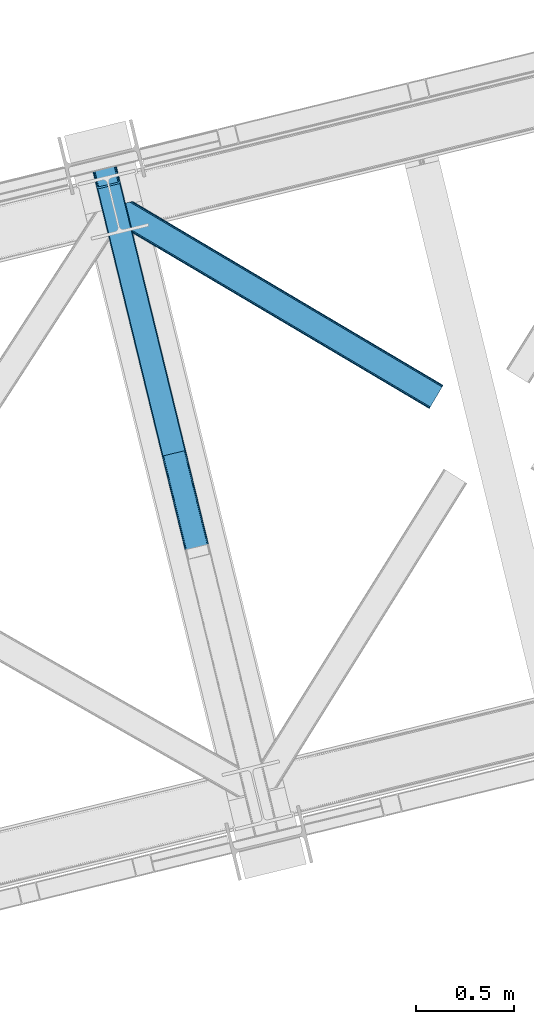
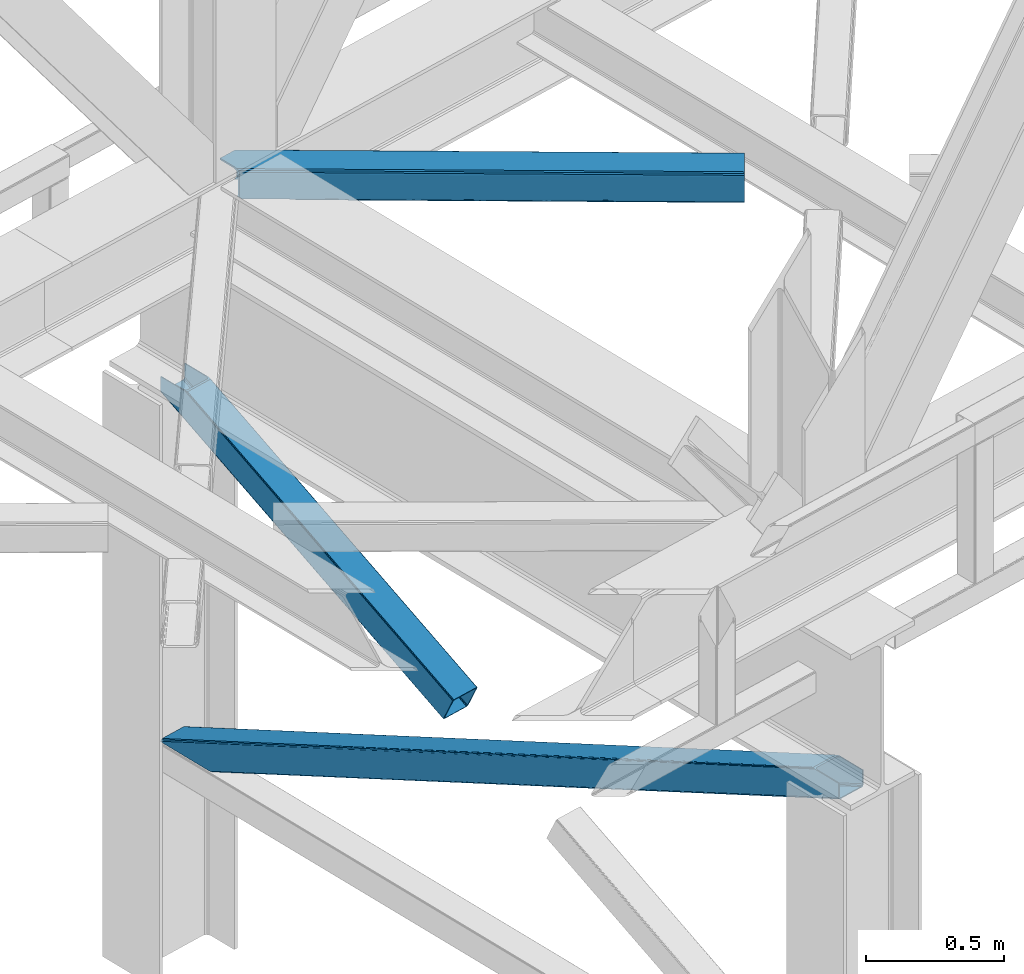
# One storey, part 56 of 93: 3 members.
"""IFC4 building model written with IfcOpenShell, lengths in millimetres."""

from ifc_helpers import new_model, entity, si_unit, converted_unit, derived_unit, direction, frame, origin, place, context, subcontext, project, spatial, triangles, polygons, type_object, element, save


model = new_model("IFC4")

# Units and contexts
model_context = context("Model", 3, precision=0.01, world=origin(), true_north=direction((6.12303176911189e-17, 1.0)))
plan_context = context("Plan", 3, precision=0.01, world=origin(), true_north=direction((6.12303176911189e-17, 1.0)))
body_context = subcontext(model_context, "Body", "Model", "MODEL_VIEW")
ifc_project = project(units=[si_unit("LENGTHUNIT", "METRE", prefix="MILLI"), si_unit("AREAUNIT", "SQUARE_METRE"), si_unit("VOLUMEUNIT", "CUBIC_METRE"), converted_unit("PLANEANGLEUNIT", "DEGREE", entity("IfcRatioMeasure", 0.0174532925199433), si_unit("PLANEANGLEUNIT", "RADIAN"), dimensions=[0, 0, 0, 0, 0, 0, 0]), si_unit("MASSUNIT", "GRAM", prefix="KILO"), derived_unit("MASSDENSITYUNIT", [(si_unit("MASSUNIT", "GRAM", prefix="KILO"), 1), (si_unit("LENGTHUNIT", "METRE"), -3)]), derived_unit("MOMENTOFINERTIAUNIT", [(si_unit("LENGTHUNIT", "METRE"), 4)]), si_unit("TIMEUNIT", "SECOND"), si_unit("FREQUENCYUNIT", "HERTZ"), si_unit("THERMODYNAMICTEMPERATUREUNIT", "DEGREE_CELSIUS"), derived_unit("THERMALTRANSMITTANCEUNIT", [(si_unit("MASSUNIT", "GRAM", prefix="KILO"), 1), (si_unit("THERMODYNAMICTEMPERATUREUNIT", "KELVIN"), -1), (si_unit("TIMEUNIT", "SECOND"), -3)]), derived_unit("VOLUMETRICFLOWRATEUNIT", [(si_unit("LENGTHUNIT", "METRE"), 3), (si_unit("TIMEUNIT", "SECOND"), -1)]), derived_unit("MASSFLOWRATEUNIT", [(si_unit("MASSUNIT", "GRAM", prefix="KILO"), 1), (si_unit("TIMEUNIT", "SECOND"), -1)]), derived_unit("ROTATIONALFREQUENCYUNIT", [(si_unit("TIMEUNIT", "SECOND"), -1)]), si_unit("ELECTRICCURRENTUNIT", "AMPERE"), si_unit("ELECTRICVOLTAGEUNIT", "VOLT"), si_unit("POWERUNIT", "WATT"), si_unit("FORCEUNIT", "NEWTON", prefix="KILO"), si_unit("ILLUMINANCEUNIT", "LUX"), si_unit("LUMINOUSFLUXUNIT", "LUMEN"), si_unit("LUMINOUSINTENSITYUNIT", "CANDELA"), derived_unit("USERDEFINED", [(si_unit("MASSUNIT", "GRAM", prefix="KILO"), -1), (si_unit("LENGTHUNIT", "METRE"), -2), (si_unit("TIMEUNIT", "SECOND"), 3), (si_unit("LUMINOUSFLUXUNIT", "LUMEN"), 1)]), derived_unit("LINEARVELOCITYUNIT", [(si_unit("LENGTHUNIT", "METRE"), 1), (si_unit("TIMEUNIT", "SECOND"), -1)]), si_unit("PRESSUREUNIT", "PASCAL"), derived_unit("USERDEFINED", [(si_unit("LENGTHUNIT", "METRE"), -2), (si_unit("MASSUNIT", "GRAM", prefix="KILO"), 1), (si_unit("TIMEUNIT", "SECOND"), -2)]), derived_unit("LINEARFORCEUNIT", [(si_unit("MASSUNIT", "GRAM", prefix="KILO"), 1), (si_unit("LENGTHUNIT", "METRE"), 1), (si_unit("TIMEUNIT", "SECOND"), -2), (si_unit("LENGTHUNIT", "METRE"), -1)]), derived_unit("PLANARFORCEUNIT", [(si_unit("MASSUNIT", "GRAM", prefix="KILO"), 1), (si_unit("LENGTHUNIT", "METRE"), 1), (si_unit("TIMEUNIT", "SECOND"), -2), (si_unit("LENGTHUNIT", "METRE"), -2)])], contexts=[model_context, plan_context])

# Site, building, storey
site_placement = place(None, origin())
site = spatial("IfcSite", under=ifc_project, at=site_placement, CompositionType="ELEMENT")
building_placement = place(site_placement, origin())
building = spatial("IfcBuilding", under=site, at=building_placement, CompositionType="ELEMENT")
storey_placement = place(building_placement, frame((0.0, 0.0, 15900.0)))
storey = spatial("IfcBuildingStorey", under=building, at=storey_placement, CompositionType="ELEMENT", Elevation=15900.0)

# Members
member_type_1 = type_object("IfcMemberType", PredefinedType="BRACE")
member_1_placement = place(storey_placement, frame((-30279.2253679732, 12158.5406038661, 1820.90870290301)))
element("IfcMember", 1, at=member_1_placement, inside=storey, type_object=member_type_1, ObjectType="Steel Vertical Brace", PredefinedType="BRACE", context=body_context, shape_type="Tessellation", body=[
    polygons([(29.8135191782847, 1388.61826467864, 771.091297096984), (32.1113287327985, 1381.7631169139, 771.091297096991), (368.111452939622, 3.36089743274636, 105.060837153753), (367.211709770158, 4.48063717440627, 102.289544138114), (35.2425975620341, 1376.24004026086, 771.091297096982), (370.057498317433, 2.70006492288447, 107.410225929579), (38.7306183717297, 1372.88987307312, 771.091297096984), (372.753578135712, 2.59874540397378, 108.980037321763), (42.0443716126254, 1372.22264793569, 771.091297096984), (375.789238682203, 3.07236385431457, 109.531281776207), (140.171129484908, 1396.14208332771, 771.091297096984), (473.91599655449, 26.9917992463367, 109.531281776209), (142.806126265313, 1398.25937921937, 771.091297096991), (476.829086029299, 27.9682515502241, 108.980037321767), (144.361212211709, 1402.83885703392, 771.091297096989), (479.176112967103, 29.2988816959484, 107.410225929583), (144.599639585688, 1409.18333278718, 771.091297096997), (480.599763792512, 30.7811133060244, 105.060837153757), (143.485109980843, 1416.32691755851, 771.091297096984), (480.883300572716, 32.1892900542756, 102.289544138114), (149.600536198007, 1408.12910918704, 771.091297096982), (121.444007267685, 1523.63806044727, 771.091297096982), (117.557799035124, 1522.69075607531, 771.09129709698), (3.88620823256572, 1494.98210319544, 771.091297096982), (4.33146851719357e-12, 1494.03479882348, 771.091297096982), (28.1565289303171, 1378.52584756325, 771.091297096982), (30.4543384848396, 1371.67069979849, 771.091297096982), (33.5856073140622, 1366.14762314545, 771.091297096982), (37.0736281237621, 1362.79745595771, 771.091297096984), (40.3873813646535, 1362.13023082029, 771.09129709698), (146.286555702076, 1387.94427495624, 771.09129709698), (148.921552482481, 1390.06157084789, 771.091297096984), (150.476638428877, 1394.64104866244, 771.09129709698), (150.715065802839, 1400.9855244157, 771.09129709698), (359.725704690142, 52.0811507006333, 4.33146851719357e-12), (465.62487902756, 77.8951948365822, 2.16573425859679e-12), (468.660539574047, 78.3688132869209, 0.551244454446396), (471.356619392343, 78.2674937680102, 2.12105584662818), (473.302664770137, 77.6066612581461, 4.4704446224671), (474.202407939605, 76.4869215164862, 7.24173763810153), (485.172065028735, 31.4851533942308, 105.910412957166), (484.888528248512, 30.0769766459796, 108.681705972796), (483.464877423122, 28.5947450359037, 111.031094748631), (481.117850485317, 27.264114890175, 112.600906140819), (478.204761010512, 26.2876625862897, 113.152150595261), (372.305586673086, 0.473618450342957, 113.152150595257), (369.269926126603, 2.16573425859679e-12, 112.600906140819), (366.573846308307, 0.101319518910685, 111.031094748635), (364.627800930509, 0.76215202877691, 108.681705972796), (363.728057761041, 1.88189177043682, 105.910412957166), (352.758400671911, 46.8836598926922, 7.24173763810153), (353.041937452142, 48.2918366409434, 4.4704446224671), (354.465588277524, 49.7740682510194, 2.12105584662385), (356.812615215332, 51.1046983967459, 0.551244454448562), (470.718755930487, 73.8881761125124, 10.8626064571491), (469.819012761023, 75.0079158541745, 8.09131344151462), (467.872967383238, 75.6687483640451, 5.74192466567137), (465.176887564938, 75.7700678829471, 4.17211327349608), (462.141227018446, 75.2964494326106, 3.62086881905185), (364.01446914616, 51.3770140405885, 3.62086881905185), (361.101379671355, 50.4005617367011, 4.17211327349392), (358.754352733542, 49.0699315909703, 5.7419246656757), (357.330701908156, 47.5876999808965, 8.09131344151245), (357.047165127938, 46.1795232326431, 10.8626064571491), (3.88620823256139, 1494.98210319544, 710.909831470177), (117.557799035124, 1522.69075607531, 710.909831470177), (11.6586246977015, 1496.87671193937, 702.072173549059), (8.91066050334255, 1496.2068665941, 703.366418586696), (6.1626963089966, 1495.53702124884, 704.660663624352), (5.02445227078549, 1495.25956222214, 707.785247547262), (116.4195549969, 1522.41329704861, 707.785247547264), (115.281310958689, 1522.13583802191, 704.660663624352), (112.533346764338, 1521.46599267665, 703.3664185867), (109.785382569988, 1520.79614733139, 702.072173549057), (120.30576322947, 1523.36060142057, 703.366418586702), (119.167519191254, 1523.08314239387, 700.241834663787), (116.419554996908, 1522.41329704861, 698.94758962614), (113.671590802554, 1521.74345170335, 697.653344588497), (7.77241646513577, 1495.9294075674, 697.653344588497), (5.02445227078549, 1495.25956222214, 698.94758962614), (2.27648807643521, 1494.58971687688, 700.241834663785), (1.13824403821544, 1494.31225785018, 703.366418586702), (4.33146851719357e-12, 1494.03479882348, 706.491002509615), (121.44400726769, 1523.63806044727, 706.491002509615)], [[[1, 2, 3, 4]], [[2, 5, 6, 3]], [[5, 7, 8, 6]], [[7, 9, 10, 8]], [[9, 11, 12, 10]], [[11, 13, 14, 12]], [[13, 15, 16, 14]], [[15, 17, 18, 16]], [[17, 19, 20, 18]], [[21, 22, 23, 19, 17, 15, 13, 11, 9, 7, 5, 2, 1, 24, 25, 26, 27, 28, 29, 30, 31, 32, 33, 34]], [[35, 36, 37, 38, 39, 40, 41, 42, 43, 44, 45, 46, 47, 48, 49, 50, 51, 52, 53, 54], [55, 56, 57, 58, 59, 60, 61, 62, 63, 64, 4, 3, 6, 8, 10, 12, 14, 16, 18, 20]], [[24, 1, 4, 64, 65]], [[19, 23, 66, 55, 20]], [[61, 67, 68]], [[62, 68, 69]], [[63, 69, 70]], [[64, 70, 65]], [[70, 64, 63]], [[69, 63, 62]], [[68, 62, 61]], [[67, 61, 60]], [[55, 71, 56]], [[56, 72, 57]], [[57, 73, 58]], [[58, 74, 59]], [[74, 58, 73]], [[73, 57, 72]], [[72, 56, 71]], [[71, 55, 66]], [[74, 67, 60, 59]], [[75, 76, 77, 78, 79, 80, 81, 82, 83, 25, 24, 65, 70, 69, 68, 67, 74, 73, 72, 71, 66, 23, 22, 84]], [[30, 29, 47, 46]], [[29, 28, 48, 47]], [[28, 27, 49, 48]], [[27, 26, 50, 49]], [[45, 31, 30, 46]], [[21, 34, 42, 41]], [[34, 33, 43, 42]], [[33, 32, 44, 43]], [[32, 31, 45, 44]], [[50, 26, 25, 83, 51]], [[84, 22, 21, 41, 40]], [[51, 82, 52]], [[52, 81, 53]], [[53, 80, 54]], [[54, 79, 35]], [[79, 54, 80]], [[80, 53, 81]], [[81, 52, 82]], [[82, 51, 83]], [[37, 78, 77]], [[38, 77, 76]], [[39, 76, 75]], [[40, 75, 84]], [[75, 40, 39]], [[76, 39, 38]], [[77, 38, 37]], [[78, 37, 36]], [[35, 79, 78, 36]]], closed=True),
])
member_type_2 = type_object("IfcMemberType", PredefinedType="BRACE")
member_2_placement = place(storey_placement, frame((-30279.2238830566, 10185.5922363281, 970.500476074218)))
element("IfcMember", 2, at=member_2_placement, inside=storey, type_object=member_type_2, ObjectType="Steel Vertical Brace", PredefinedType="BRACE", context=body_context, shape_type="Tessellation", body=[
    triangles([(177.814727783203, 3231.5446105957, 0.0), (958.785662841798, 27.7087738037098, 1548.06132202148), (852.885150146485, 1.89407043456958, 1548.06132202148), (71.9165405273452, 3205.72990722656, 0.0), (961.532006835936, 28.3785003662106, 1549.35542907715), (964.278350830078, 29.0482269287095, 1550.65069885254), (180.449450683594, 3233.66076049805, 0.0), (965.417816162109, 29.3249542236317, 1553.77492675781), (182.005169677734, 3238.24071350098, 0.0), (966.557281494141, 29.6028442382813, 1556.89915466309), (182.242364501952, 3244.58567504883, 0.0), (181.128479003906, 3251.72942504883, 0.0), (845.113531494142, 0.0, 1556.89915466309), (59.6847290039077, 3222.12541809082, 0.0), (61.9845886230469, 3215.27118530273, 0.0), (846.250671386719, 0.27672729492042, 1553.77492675781), (65.1146301269546, 3209.74710388183, 0.0), (847.387811279295, 0.554617309569949, 1550.65069885254), (68.6004638671875, 3206.39730834961, 0.0), (850.138806152343, 1.22434387206886, 1549.35542907715), (121.443749999999, 3496.58657226562, 2.0998718261726), (938.400860595702, 145.112072753906, 1621.4998626709), (121.443749999999, 3496.58657226562, 0.0), (966.557281494141, 29.6028442382813, 1621.4998626709), (0.0, 3466.98372802734, 2.0998718261726), (816.957110595704, 115.509228515624, 1621.4998626709), (0.0, 3466.98372802734, 0.0), (845.113531494142, 0.0, 1621.4998626709), (116.418475341798, 3495.36106567383, 9.64359741210865), (113.669805908205, 3494.69250183105, 10.9377044677749), (926.169049072265, 161.507583618164, 1621.4998626709), (119.164819335936, 3496.03079223633, 8.34949035644604), (929.482800292968, 160.840182495116, 1621.4998626709), (120.304284667967, 3496.30868225098, 5.22409973144386), (932.970959472656, 157.490386962891, 1621.4998626709), (936.101000976563, 151.967468261719, 1621.4998626709), (7.77161865234302, 3468.87779846191, 10.9377044677749), (820.270861816407, 135.694042968749, 1621.4998626709), (815.843225097655, 122.652978515624, 1621.4998626709), (1.13481445312573, 3467.26045532226, 5.22409973144386), (816.078094482422, 128.996777343749, 1621.4998626709), (2.27427978515698, 3467.53834533691, 8.34949035644604), (817.633813476561, 133.575567626953, 1621.4998626709), (5.02294921875, 3468.20807189941, 9.64359741210865), (4.15556030273365, 3467.99645690918, 0.0), (4.76482543945167, 3468.14528503418, 0.782510375975107), (6.74609985351708, 3468.6278137207, 3.34281921386719), (117.283538818359, 3495.57268066406, 0.0), (116.797521972658, 3495.45408325195, 0.95459289550854), (115.279010009766, 3495.08433837891, 3.92999267578125), (8.68086547851635, 3469.09987792969, 5.84615478515479), (109.783996582031, 3493.74488525391, 6.51936950683739), (11.6574279785164, 3469.82541503906, 6.51936950683739), (112.532666015624, 3494.41461181641, 5.22409973144386), (924.513336181641, 151.415176391602, 1621.4998626709), (826.384442138671, 127.495706176756, 1621.4998626709), (118.725311279297, 3490.84157409668, 0.0), (936.742822265624, 135.019665527343, 1621.4998626709), (934.445288085939, 141.875061035156, 1621.4998626709), (931.312921142577, 147.397979736328, 1621.4998626709), (927.824761962889, 150.747775268554, 1621.4998626709), (962.671472167967, 28.6552276611328, 1621.4998626709), (822.194000244141, 120.798440551756, 1621.4998626709), (823.74971923828, 125.378393554687, 1621.4998626709), (823.070690917968, 107.310891723631, 1621.4998626709), (821.956805419923, 114.454641723632, 1621.4998626709), (848.999340820312, 0.947616577148438, 1621.4998626709), (5.05550537109229, 3463.13280029297, 0.0), (175.014898681642, 3259.92659912109, 0.0), (962.671472167967, 28.6552276611328, 1561.31865234375), (61.3427673339829, 3232.21782531738, 0.0), (848.999340820312, 0.947616577148438, 1561.31865234375), (66.7703430175789, 3219.8395111084, 0.0), (63.6403015136711, 3225.3635925293, 0.0), (70.2585021972664, 3216.48971557617, 0.0), (73.5722534179695, 3215.82231445312, 0.0), (175.889263916015, 3246.43905029297, 0.0), (176.128784179688, 3252.78284912109, 0.0), (174.333544921876, 3241.85909729004, 0.0), (171.701147460939, 3239.74178466797, 0.0), (954.897528076173, 26.7611572265614, 1552.48081970215), (957.646197509766, 27.4308837890621, 1553.77492675781), (960.392541503905, 28.100610351561, 1555.06903381348), (856.770959472655, 2.84168701171802, 1552.48081970215), (854.024615478516, 2.17196044921729, 1553.77492675781), (851.273620605469, 1.50223388671839, 1555.06903381348), (961.532006835936, 28.3785003662106, 1558.19326171875), (850.138806152343, 1.22434387206886, 1558.19326171875)], [[1, 2, 3], [3, 4, 1], [5, 2, 1], [6, 5, 7], [8, 6, 9], [10, 8, 11], [11, 12, 10], [9, 11, 8], [7, 9, 6], [1, 7, 5], [13, 14, 15], [16, 15, 17], [18, 17, 19], [20, 19, 4], [4, 3, 20], [19, 20, 18], [17, 18, 16], [15, 16, 13], [12, 21, 22], [12, 23, 21], [22, 10, 12], [24, 10, 22], [25, 14, 26], [14, 25, 27], [13, 26, 14], [28, 26, 13], [29, 30, 31], [32, 29, 33], [34, 32, 35], [21, 34, 36], [36, 22, 21], [35, 36, 34], [33, 35, 32], [31, 33, 29], [31, 30, 37], [37, 38, 31], [25, 26, 39], [40, 39, 41], [42, 41, 43], [44, 43, 38], [38, 37, 44], [43, 44, 42], [41, 42, 40], [39, 40, 25], [45, 25, 46], [45, 27, 25], [46, 40, 47], [40, 42, 47], [25, 40, 46], [48, 21, 23], [21, 48, 49], [49, 34, 21], [34, 49, 50], [47, 44, 51], [37, 30, 52], [53, 51, 37], [52, 53, 37], [51, 44, 37], [42, 44, 47], [30, 54, 52], [29, 50, 54], [50, 32, 34], [50, 29, 32], [30, 29, 54], [52, 55, 56], [56, 53, 52], [57, 58, 59], [49, 48, 57], [49, 59, 60], [50, 60, 61], [54, 61, 55], [55, 52, 54], [61, 54, 50], [60, 50, 49], [59, 49, 57], [61, 60, 36], [35, 61, 36], [61, 35, 33], [55, 31, 38], [33, 55, 61], [31, 55, 33], [60, 22, 36], [24, 58, 62], [24, 22, 58], [60, 59, 22], [59, 58, 22], [39, 63, 64], [38, 56, 55], [56, 43, 64], [43, 56, 38], [64, 41, 39], [41, 64, 43], [26, 63, 39], [65, 66, 26], [66, 63, 26], [65, 28, 67], [26, 28, 65], [47, 51, 64], [46, 47, 63], [68, 46, 66], [66, 65, 68], [68, 45, 46], [63, 66, 46], [64, 63, 47], [53, 56, 51], [64, 51, 56], [58, 69, 70], [58, 57, 69], [70, 62, 58], [71, 65, 72], [65, 71, 68], [67, 72, 65], [73, 15, 14], [27, 68, 71], [68, 27, 45], [14, 71, 74], [71, 14, 27], [74, 73, 14], [75, 15, 73], [17, 75, 19], [17, 15, 75], [19, 76, 4], [4, 76, 1], [75, 76, 19], [12, 11, 77], [78, 69, 12], [77, 78, 12], [23, 57, 48], [69, 23, 12], [57, 23, 69], [11, 79, 77], [80, 7, 1], [80, 1, 76], [80, 79, 7], [79, 9, 7], [79, 11, 9], [81, 3, 2], [2, 5, 82], [6, 83, 5], [83, 82, 5], [2, 82, 81], [83, 6, 8], [84, 3, 81], [20, 85, 86], [20, 3, 85], [86, 18, 20], [18, 86, 16], [84, 85, 3], [87, 10, 70], [8, 87, 83], [10, 87, 8], [24, 70, 10], [24, 62, 70], [16, 88, 13], [13, 88, 72], [86, 88, 16], [72, 28, 13], [28, 72, 67], [81, 80, 76], [76, 84, 81], [70, 69, 78], [87, 78, 77], [83, 77, 79], [82, 79, 80], [80, 81, 82], [79, 82, 83], [77, 83, 87], [78, 87, 70], [85, 84, 76], [86, 85, 75], [88, 86, 73], [72, 88, 74], [74, 71, 72], [73, 74, 88], [75, 73, 86], [76, 75, 85]]),
])
member_type_3 = type_object("IfcMemberType", PredefinedType="BRACE")
member_3_placement = place(storey_placement, frame((-30155.6011962891, 12399.0652679443, 3510.00011901855)))
element("IfcMember", 3, at=member_3_placement, inside=storey, type_object=member_type_3, ObjectType="Steel Horizontal Brace", PredefinedType="BRACE", context=body_context, shape_type="Tessellation", body=[
    triangles([(1674.92102050781, 120.470553588868, 122.500662231447), (1674.92102050781, 120.470553588868, 17.5000946044929), (91.5037170410142, 1057.89356689453, 17.5000946044929), (91.5037170410142, 1057.89356689453, 122.500662231447), (1666.00761108398, 105.412170410156, 139.999594116212), (1669.41903076172, 111.174609375001, 138.667117309571), (76.4813781738267, 1054.23099975586, 138.667117309571), (67.1726440429666, 1051.96137084961, 139.999594116212), (1672.31187744141, 116.060357666016, 134.874325561526), (84.376245117186, 1056.15530090332, 134.874325561526), (1674.24431762695, 119.325274658204, 129.197927856447), (89.6526672363252, 1057.4412689209, 129.197927856447), (18.7686218261697, 958.594976806642, 139.999594116212), (1612.51552734375, 15.059545898439, 139.999594116212), (0.0, 1035.58795166016, 139.999594116212), (1603.59979248047, 0.0, 122.500662231447), (1604.27882080078, 1.14644165039135, 129.197927856447), (24.5636169433565, 934.827822875977, 122.500662231447), (24.1217834472627, 936.637014770509, 129.197927856447), (1606.21126098633, 4.41135864257922, 134.874325561526), (22.8660461425752, 941.789025878907, 134.874325561526), (1609.10410766601, 9.29594421386719, 138.667117309571), (20.9870910644531, 949.499020385743, 138.667117309571), (1603.59979248047, 0.0, 17.5000946044929), (24.5636169433565, 934.827822875977, 17.5000946044929), (1674.24431762695, 119.325274658204, 10.8028289794929), (89.5643005371094, 1057.42033996582, 10.8167816162131), (162.741229248044, 1014.02182617188, 10.5005218505867), (1672.31187744141, 116.060357666016, 5.12526855468968), (165.157360839843, 1008.33263854981, 5.12526855468968), (164.099285888671, 1012.66493225098, 9.50058288574292), (163.771398925779, 1012.99281921387, 9.74126586914281), (163.420257568359, 1013.34396057129, 10.0005523681648), (163.066790771481, 1013.69510192871, 10.2586761474631), (89.4712829589844, 1057.39708557129, 10.5005218505867), (1669.41903076172, 111.174609375001, 1.33247680664135), (167.036315917969, 1000.62264404297, 1.33247680664135), (1666.00761108398, 105.412170410156, 0.0), (169.252459716794, 991.527850341798, 0.0), (1612.51552734375, 15.059545898439, 0.0), (204.013128662107, 848.927252197267, 0.0), (166.892138671872, 996.992633056641, 10.5005218505867), (72.0374633789033, 1053.14850769043, 10.5005218505867), (168.587384033202, 994.262567138672, 9.50058288574292), (168.16880493164, 994.934619140626, 9.74591674804833), (167.738598632812, 995.627600097658, 10.0005523681648), (167.306066894529, 996.319418334962, 10.2540252685576), (1668.74465332031, 110.037469482422, 12.1260040283232), (1670.67709350586, 113.301223754883, 17.8035644531265), (79.9183776855461, 1055.06932067871, 17.8035644531265), (1665.85180664063, 105.151721191407, 8.3320495605476), (169.401287841796, 990.919747924805, 8.81690368652562), (74.1164062499993, 1053.65429077148, 12.4271484375022), (171.570922851563, 982.021453857422, 6.99957275390625), (1662.44038696289, 99.388119506837, 6.99957275390625), (1671.35612182617, 114.447665405274, 24.4996673583992), (81.771752929686, 1055.52045593262, 24.4996673583992), (1671.35612182617, 114.447665405274, 115.501089477541), (81.771752929686, 1055.52045593262, 115.501089477541), (74.6442810058579, 1053.78335266113, 127.87475280762), (66.7494140624985, 1051.85905151367, 131.667544555665), (79.9183776855461, 1055.06932067871, 122.196029663086), (57.4383544921875, 1049.58942260742, 133.000021362306), (0.0, 1035.58795166016, 133.000021362306), (1670.67709350586, 113.301223754883, 122.196029663086), (1668.74465332031, 110.037469482422, 127.87475280762), (1665.85180664063, 105.151721191407, 131.667544555665), (1662.44038696289, 99.388119506837, 133.000021362306), (16.4524841308594, 968.101373291016, 133.000021362306), (1616.08042602539, 21.0824340820327, 133.000021362306), (1616.08042602539, 21.0824340820327, 6.99957275390625), (201.696990966797, 858.433648681641, 6.99957275390625), (1609.77848510742, 10.434246826173, 127.87475280762), (1612.66900634766, 15.3199951171882, 131.667544555665), (1607.16701660156, 6.02405090332104, 115.501089477541), (1607.84371948242, 7.1693298339851, 122.196029663086), (1609.10410766601, 9.29594421386719, 1.33247680664135), (1609.77848510742, 10.434246826173, 12.1260040283232), (1606.21126098633, 4.41135864257922, 5.12526855468968), (1612.66900634766, 15.3199951171882, 8.3320495605476), (1604.27882080078, 1.14644165039135, 10.8028289794929), (1607.16701660156, 6.02405090332104, 24.4996673583992), (1607.84371948242, 7.1693298339851, 17.8035644531265), (18.6686279296846, 959.006579589844, 131.667544555665), (20.5475830078103, 951.295422363282, 127.87475280762), (21.8033203124978, 946.143411254883, 122.196029663086), (22.2451538085916, 944.334219360353, 115.501089477541), (22.2451538085916, 944.334219360353, 24.4996673583992), (21.7823913574211, 946.22945251465, 17.8163543701194), (21.7614624023408, 946.318981933595, 17.5000946044929), (203.864300537109, 849.535354614258, 8.81690368652562), (206.229272460936, 839.832458496094, 1.33247680664135), (204.680529785153, 846.192535400391, 9.50058288574292), (208.110552978513, 832.122463989259, 5.12526855468968), (209.166302490234, 827.789007568361, 9.50058288574292), (204.685180664063, 844.928659057618, 10.2075164794951), (204.327062988279, 844.907730102539, 10.3540191650391), (203.968945312499, 844.885638427735, 10.5005218505867), (27.0146301269524, 947.468911743164, 12.1260040283232), (28.3494323730447, 948.857199096681, 10.5005218505867), (204.682855224608, 845.561178588869, 9.85404968261719), (32.1398986816384, 931.964044189453, 10.8179443359404), (209.136071777342, 827.584368896485, 9.88311767578125), (208.119854736327, 827.857608032227, 10.5005218505867), (208.803533935545, 827.672735595705, 10.0842681884787), (32.5003417968728, 931.828005981446, 10.5005218505867)], [[1, 2, 3], [3, 4, 1], [5, 6, 7], [7, 8, 5], [6, 9, 10], [10, 7, 6], [9, 11, 12], [12, 10, 9], [11, 1, 4], [4, 12, 11], [5, 13, 14], [13, 5, 8], [15, 13, 8], [16, 17, 18], [19, 18, 17], [17, 20, 19], [21, 19, 20], [20, 22, 21], [23, 21, 22], [22, 14, 23], [13, 23, 14], [24, 16, 18], [18, 25, 24], [26, 27, 3], [27, 26, 28], [26, 29, 30], [30, 31, 26], [26, 32, 33], [32, 26, 31], [26, 34, 28], [34, 26, 33], [28, 35, 27], [29, 36, 37], [37, 30, 29], [36, 38, 39], [39, 37, 36], [3, 2, 26], [38, 40, 41], [41, 39, 38], [28, 42, 35], [43, 35, 42], [31, 44, 45], [45, 32, 31], [32, 45, 46], [46, 33, 32], [33, 46, 47], [47, 34, 33], [34, 47, 42], [42, 28, 34], [48, 49, 50], [45, 51, 46], [45, 44, 51], [42, 47, 51], [47, 46, 51], [44, 52, 51], [48, 53, 42], [42, 51, 48], [53, 43, 42], [51, 52, 54], [54, 55, 51], [50, 53, 48], [49, 56, 57], [57, 50, 49], [56, 58, 57], [59, 57, 58], [60, 61, 7], [10, 60, 7], [10, 12, 62], [60, 10, 62], [62, 12, 4], [61, 8, 7], [15, 63, 64], [15, 8, 63], [61, 63, 8], [62, 4, 59], [57, 3, 50], [4, 57, 59], [3, 27, 50], [4, 3, 57], [35, 50, 27], [35, 53, 50], [35, 43, 53], [58, 65, 59], [62, 59, 65], [65, 66, 62], [60, 62, 66], [66, 67, 60], [61, 60, 67], [67, 68, 61], [63, 61, 68], [68, 69, 63], [68, 70, 69], [69, 64, 63], [71, 55, 72], [54, 72, 55], [11, 66, 65], [58, 2, 1], [11, 65, 1], [11, 9, 66], [65, 58, 1], [66, 9, 6], [68, 5, 14], [5, 67, 6], [67, 5, 68], [67, 66, 6], [26, 48, 29], [56, 2, 58], [2, 49, 26], [49, 2, 56], [26, 49, 48], [38, 55, 40], [36, 29, 48], [48, 51, 36], [51, 55, 38], [38, 36, 51], [73, 22, 20], [14, 70, 68], [14, 74, 70], [74, 14, 22], [73, 74, 22], [75, 16, 24], [17, 76, 73], [20, 17, 73], [76, 17, 16], [75, 76, 16], [77, 78, 79], [40, 55, 71], [71, 80, 40], [80, 78, 77], [77, 40, 80], [81, 79, 78], [24, 82, 75], [83, 24, 81], [24, 83, 82], [83, 81, 78], [70, 74, 84], [84, 69, 70], [74, 73, 85], [85, 84, 74], [73, 76, 86], [86, 85, 73], [76, 75, 87], [87, 86, 76], [75, 82, 87], [88, 87, 82], [86, 87, 18], [18, 19, 86], [21, 86, 19], [86, 21, 85], [18, 88, 25], [89, 90, 25], [25, 88, 89], [87, 88, 18], [84, 23, 13], [15, 69, 13], [64, 69, 15], [84, 85, 23], [23, 85, 21], [69, 84, 13], [44, 30, 37], [39, 44, 37], [54, 52, 39], [54, 39, 72], [30, 44, 31], [39, 52, 44], [72, 41, 91], [41, 92, 93], [41, 72, 39], [94, 93, 92], [41, 93, 91], [94, 95, 93], [83, 89, 88], [71, 72, 91], [78, 96, 97], [97, 98, 78], [98, 99, 78], [98, 100, 99], [80, 91, 93], [93, 78, 80], [78, 93, 101], [101, 96, 78], [83, 78, 99], [99, 90, 83], [90, 89, 83], [91, 80, 71], [88, 82, 83], [24, 25, 102], [79, 103, 95], [81, 102, 104], [104, 79, 81], [104, 105, 79], [95, 94, 79], [40, 77, 92], [92, 41, 40], [77, 79, 94], [94, 92, 77], [106, 81, 24], [99, 106, 25], [99, 100, 106], [25, 90, 99], [98, 104, 106], [106, 100, 98]]),
])

save(model, "model.ifc")
